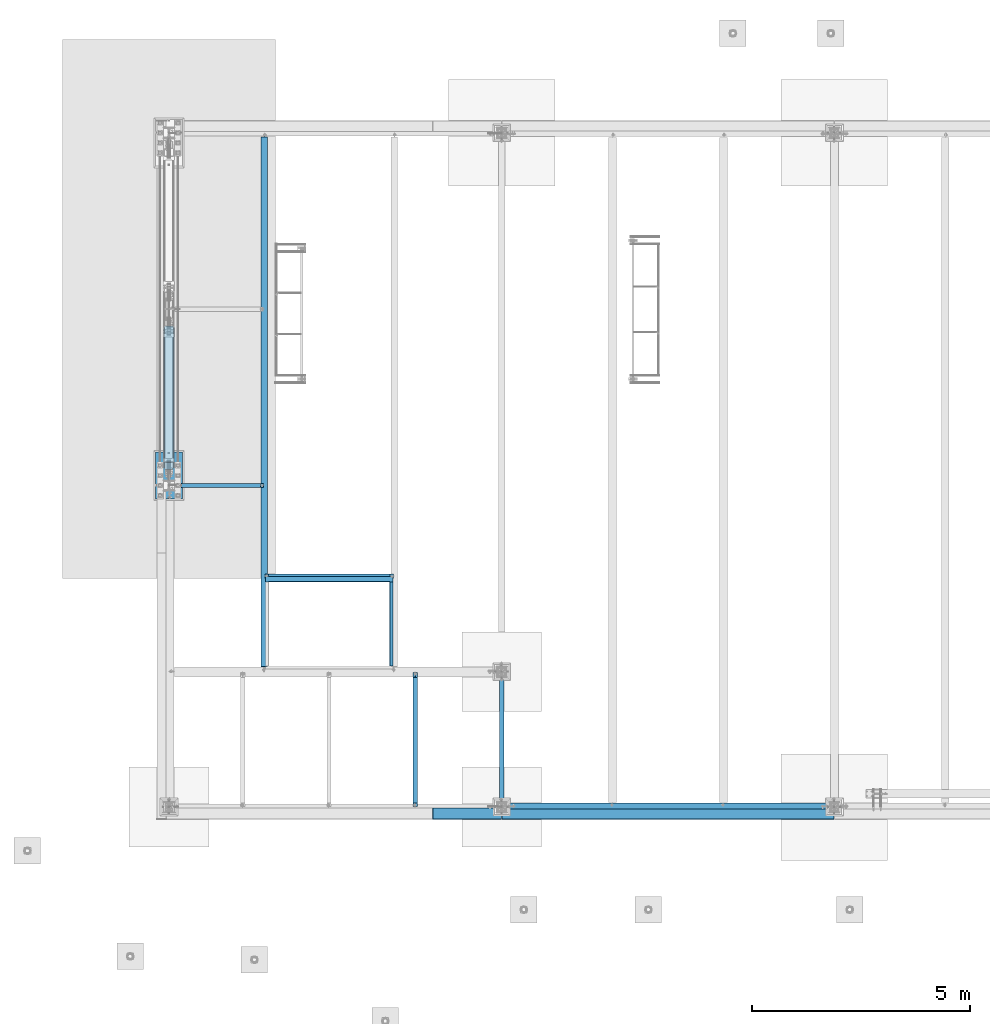
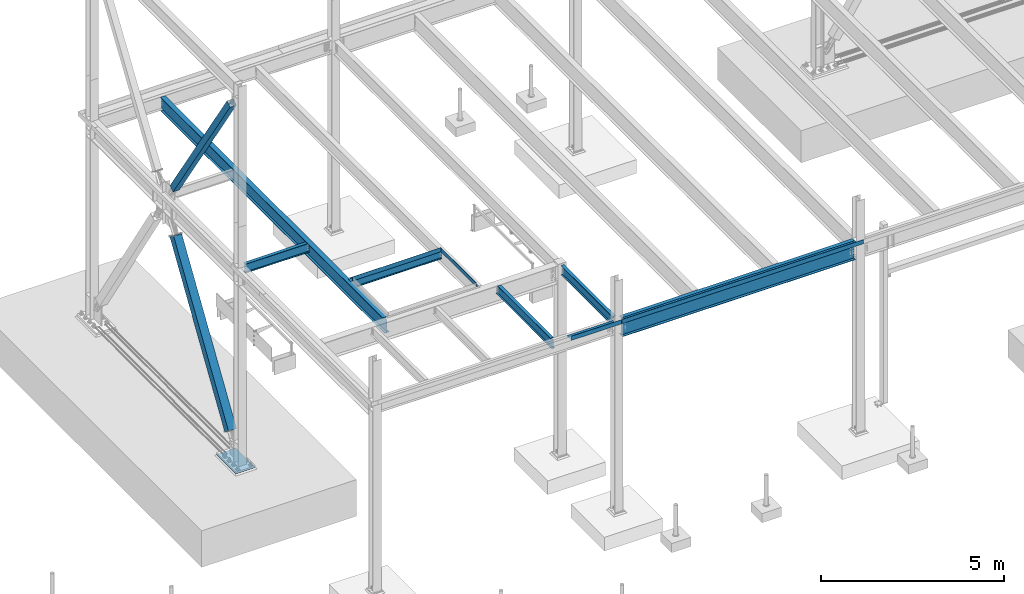
# One storey, part 1864 of 3843: 11 beams, 2 members, 11 elements without a shape of their own.
"""IFC2X3 building model written with IfcOpenShell, lengths in millimetres."""

from ifc_helpers import new_model, si_unit, frame, origin_with_axes, place, context, subcontext, project, spatial, faceted_brep, material, type_object, element, aggregate, save


model = new_model("IFC2X3")

# Units and contexts
model_context = context("Model", 3, precision=1e-05, world=origin_with_axes())
body_context = subcontext(model_context, "Body", "Model", "MODEL_VIEW")
ifc_project = project(units=[si_unit("LENGTHUNIT", "METRE", prefix="MILLI"), si_unit("AREAUNIT", "SQUARE_METRE"), si_unit("VOLUMEUNIT", "CUBIC_METRE"), si_unit("MASSUNIT", "GRAM", prefix="KILO"), si_unit("TIMEUNIT", "SECOND"), si_unit("PLANEANGLEUNIT", "RADIAN"), si_unit("SOLIDANGLEUNIT", "STERADIAN"), si_unit("THERMODYNAMICTEMPERATUREUNIT", "DEGREE_CELSIUS"), si_unit("LUMINOUSINTENSITYUNIT", "LUMEN")], contexts=[model_context])

# Site, building, storey
site_placement = place(None, origin_with_axes())
site = spatial("IfcSite", under=ifc_project, at=site_placement, CompositionType="ELEMENT")
building_placement = place(site_placement, origin_with_axes())
building = spatial("IfcBuilding", under=site, at=building_placement, Name="Undefined", CompositionType="ELEMENT")
storey_placement = place(building_placement, origin_with_axes())
storey = spatial("IfcBuildingStorey", under=building, at=storey_placement, Name="Undefined", CompositionType="ELEMENT", Elevation=0.0)

# Assembly, beam
assembly_1_placement = place(storey_placement, origin_with_axes())
assembly_1 = element("IfcElementAssembly", 1, at=assembly_1_placement, inside=storey, Name="BEAM", AssemblyPlace="NOTDEFINED", PredefinedType="RIGID_FRAME")
ifc_material_1 = material(Name="STEEL/A36")
beam_type_1 = type_object("IfcBeamType", PredefinedType="NOTDEFINED")
beam_1_placement = place(assembly_1_placement, frame((5130.8, 93306.89925, 36439.475), z_axis=(0.0, -1.0, 0.0), x_axis=(-1.0, 0.0, 0.0)))
beam_1 = element("IfcBeam", 2, at=beam_1_placement, type_object=beam_type_1, material=ifc_material_1, Name="BENT_PLATE", context=body_context, shape_type="Brep", body=[
    faceted_brep([(0.0, -3.17500000000291, -964.406000000003), (0.0, -3.17500000000291, 964.406000000003), (0.0, 3.17500000000291, 964.406000000003), (0.0, 3.17500000000291, -964.406000000003), (76.1999969482395, 3.17500000000291, 964.406000000003), (76.1999969482395, 3.17500000000291, -964.406000000003), (69.8499969482391, -3.17500000000291, -964.406000000003), (69.8499969482391, -3.17500000000291, 964.406000000003), (76.1999969482395, -136.524996948239, 964.406000000003), (76.1999969482395, -136.524996948239, -964.406000000003), (69.8499969482391, -136.524996948239, 964.406000000003), (69.8499969482391, -136.524996948239, -964.406000000003)], [[[0, 1, 2, 3]], [[3, 2, 4, 5]], [[1, 0, 6, 7]], [[5, 4, 8, 9]], [[4, 2, 1, 7, 10, 8]], [[7, 6, 11, 10]], [[6, 0, 3, 5, 9, 11]], [[10, 11, 9, 8]]]),
])
aggregate(assembly_1, [beam_1])

assembly_2_placement = place(storey_placement, origin_with_axes())
assembly_2 = element("IfcElementAssembly", 3, at=assembly_2_placement, inside=storey, Name="BEAM", AssemblyPlace="NOTDEFINED", PredefinedType="RIGID_FRAME")
ifc_material_2 = material(Name="STEEL/A992")
beam_type_2 = type_object("IfcBeamType", Name="W12X19", PredefinedType="NOTDEFINED")
beam_2_placement = place(assembly_2_placement, frame((7620.0, 89115.9, 36282.3125), z_axis=(0.0, 0.0, 1.0), x_axis=(0.0, 1.0, 0.0)))
beam_2 = element("IfcBeam", 4, at=beam_2_placement, type_object=beam_type_2, material=ifc_material_2, Name="BEAM", ObjectType="W12X19", context=body_context, shape_type="Brep", body=[
    faceted_brep([(139.699999999997, -50.8000000000002, -153.987500000003), (139.699999999997, 50.8000000000002, -153.987500000003), (2959.10000000001, 50.8000000000002, -153.987500000003), (2959.10000000001, -50.8000000000002, -153.987500000003), (139.699999999997, -50.8000000000002, -144.462500000001), (139.699999999997, -3.17500000000018, -144.462500000001), (139.699999999997, -3.17500000000018, 144.462500000001), (139.699999999997, -50.8000000000002, 144.462500000001), (139.699999999997, -50.8000000000002, 153.987500000003), (139.699999999997, 50.8000000000002, 153.987500000003), (139.699999999997, 50.8000000000002, 144.462500000001), (139.699999999997, 3.17500000000018, 144.462500000001), (139.699999999997, 3.17500000000018, -144.462500000001), (139.699999999997, 50.8000000000002, -144.462500000001), (2959.10000000001, -50.8000000000002, -144.462500000001), (2959.10000000001, -3.17500000000018, -144.462500000001), (2959.10000000001, -3.17500000000018, 144.462500000001), (2959.10000000001, -50.8000000000002, 144.462500000001), (2959.10000000001, -50.8000000000002, 153.987500000003), (2959.10000000001, 50.8000000000002, 153.987500000003), (2959.10000000001, 50.8000000000002, 144.462500000001), (2959.10000000001, 3.17500000000018, 144.462500000001), (2959.10000000001, 3.17500000000018, -144.462500000001), (2959.10000000001, 50.8000000000002, -144.462500000001)], [[[0, 1, 2, 3]], [[0, 4, 5, 6, 7, 8, 9, 10, 11, 12, 13, 1]], [[5, 4, 14, 15]], [[6, 5, 15, 16]], [[7, 6, 16, 17]], [[8, 7, 17, 18]], [[9, 8, 18, 19]], [[10, 9, 19, 20]], [[11, 10, 20, 21]], [[12, 11, 21, 22]], [[13, 12, 22, 23]], [[1, 13, 23, 2]], [[22, 21, 20, 19, 18, 17, 16, 15, 14, 3, 2, 23]], [[4, 0, 3, 14]]]),
])
aggregate(assembly_2, [beam_2])

assembly_3_placement = place(storey_placement, origin_with_axes())
assembly_3 = element("IfcElementAssembly", 5, at=assembly_3_placement, inside=storey, Name="BEAM", AssemblyPlace="NOTDEFINED", PredefinedType="RIGID_FRAME")
beam_3_placement = place(assembly_3_placement, frame((0.0, 96481.9, 36282.3125), z_axis=(0.0, 0.0, 1.0), x_axis=(1.0, 0.0, 0.0)))
beam_3 = element("IfcBeam", 6, at=beam_3_placement, type_object=beam_type_2, material=ifc_material_2, Name="BEAM", ObjectType="W12X19", context=body_context, shape_type="Brep", body=[
    faceted_brep([(2091.53125, -50.8000000000029, 153.987500000003), (2091.53125, -50.8000000000029, 144.462500000001), (2091.53125, -3.17500000000291, 144.462500000001), (2091.53125, -3.17500000000291, 141.287499809259), (2091.53125, 3.17500000000291, 141.287499809259), (2091.53125, 3.17500000000291, 144.462500000001), (2091.53125, 50.8000000000029, 144.462500000001), (2091.53125, 50.8000000000029, 153.987500000003), (2092.49797992259, -3.17500000000291, 136.427420291213), (2092.49797992259, 3.17500000000291, 136.427420291213), (2095.25099382307, -3.17500000000291, 132.307243823059), (2095.25099382307, 3.17500000000291, 132.307243823059), (2099.37117029122, -3.17500000000291, 129.554229922585), (2099.37117029122, 3.17500000000291, 129.554229922585), (2104.23124980927, -3.17500000000291, 128.587499999994), (2104.23124980927, 3.17500000000291, 128.587499999994), (2167.73125, -3.17500000000291, 128.587499999994), (2167.73125, 3.17500000000291, 128.587499999994), (141.2875, -50.8000000000029, -153.987500000003), (141.2875, -50.8000000000029, -144.462500000001), (141.2875, -3.17500000000291, -144.462500000001), (141.2875, -3.17500000000291, 144.462500000001), (141.2875, -50.8000000000029, 144.462500000001), (141.2875, -50.8000000000029, 153.987500000003), (141.2875, 50.8000000000029, 153.987500000003), (141.2875, 50.8000000000029, 144.462500000001), (141.2875, 3.17500000000291, 144.462500000001), (141.2875, 3.17500000000291, 116.627499998925), (141.2875, 3.17500000000291, -113.45249999997), (141.2875, 3.17500000000291, -144.462500000001), (141.2875, 50.8000000000029, -144.462500000001), (141.2875, 50.8000000000029, -153.987500000003), (2167.73125, 3.17500000000291, -144.462500000001), (2167.73125, 50.8000000000029, -144.462500000001), (2167.73125, 50.8000000000029, -153.987500000003), (2167.73125, -50.8000000000029, -153.987500000003), (2167.73125, -50.8000000000029, -144.462500000001), (2167.73125, -3.17500000000291, -144.462500000001), (2167.73125, 3.17500000000291, 115.887499999997), (2167.73125, 3.17500000000291, -114.712500000001)], [[[0, 1, 2, 3, 4, 5, 6, 7]], [[8, 9, 4, 3]], [[10, 11, 9, 8]], [[12, 13, 11, 10]], [[14, 15, 13, 12]], [[16, 17, 15, 14]], [[18, 19, 20, 21, 22, 23, 24, 25, 26, 27, 28, 29, 30, 31]], [[30, 29, 32, 33]], [[31, 30, 33, 34]], [[18, 31, 34, 35]], [[19, 18, 35, 36]], [[20, 19, 36, 37]], [[12, 10, 8, 3, 2, 21, 20, 37, 16, 14]], [[22, 21, 2, 1]], [[23, 22, 1, 0]], [[24, 23, 0, 7]], [[25, 24, 7, 6]], [[26, 25, 6, 5]], [[38, 39, 32, 29, 28, 27, 26, 5, 4, 9, 11, 13, 15, 17]], [[37, 36, 35, 34, 33, 32, 39, 38, 17, 16]]]),
])
aggregate(assembly_3, [beam_3])

assembly_4_placement = place(storey_placement, origin_with_axes())
assembly_4 = element("IfcElementAssembly", 7, at=assembly_4_placement, inside=storey, Name="BEAM", AssemblyPlace="NOTDEFINED", PredefinedType="RIGID_FRAME")
beam_4_placement = place(assembly_4_placement, frame((5638.8, 89115.9, 36282.3125), z_axis=(0.0, 0.0, 1.0), x_axis=(0.0, 1.0, 0.0)))
beam_4 = element("IfcBeam", 8, at=beam_4_placement, type_object=beam_type_2, material=ifc_material_2, Name="BEAM", ObjectType="W12X19", context=body_context, shape_type="Brep", body=[
    faceted_brep([(2972.59375, -50.8000000000002, 153.987499993149), (2972.59375, -50.8000000000002, 144.462500000001), (2972.59375, -3.17500000000018, 144.462500000001), (2972.59375, -3.17500000000018, 141.287499809267), (2972.59375, 3.17500000000018, 141.287499809267), (2972.59375, 3.17500000000018, 144.462500000001), (2972.59375, 50.8000000000002, 144.462500000001), (2972.59375, 50.8000000000002, 153.987500000003), (2973.56047992258, -3.17500000000018, 136.42742029122), (2973.56047992258, 3.17500000000018, 136.42742029122), (2976.31349382307, -3.17500000000018, 132.307243823067), (2976.31349382307, 3.17500000000018, 132.307243823067), (2980.43367029123, -3.17500000000018, 129.554229922593), (2980.43367029123, 3.17500000000018, 129.554229922593), (2985.29374980927, -3.17500000000018, 128.587500000001), (2985.29374980927, 3.17500000000018, 128.587500000001), (3080.54375, -3.17500000000018, 128.587500000001), (3080.54375, 3.17500000000018, 128.587500000001), (92.8687499999796, -50.8000000000002, 153.987499810319), (92.8687499999796, 50.8000000000002, 153.987500000003), (92.8687499999796, 50.8000000000002, 144.462500000001), (92.8687499999796, 3.17500000000018, 144.462500000001), (92.8687499999796, 3.17500000000018, 141.287499809259), (92.8687499999796, -3.17500000000018, 141.287499809259), (92.8687499999796, -3.17500000000018, 144.462500000001), (92.8687499999796, -50.8000000000002, 144.462500000001), (91.9020200773957, 3.17500000000018, 136.427420291213), (91.9020200773957, -3.17500000000018, 136.427420291213), (89.1490061769146, 3.17500000000018, 132.307243823059), (89.1490061769146, -3.17500000000018, 132.307243823059), (85.0288297087536, 3.17500000000018, 129.554229922585), (85.0288297087536, -3.17500000000018, 129.554229922585), (80.1687501907145, 3.17500000000018, 128.587499999994), (80.1687501907145, -3.17500000000018, 128.587499999994), (16.6687499999971, 3.17499999999927, 128.587500000001), (16.6687499999971, -3.17499999999927, 128.587500000001), (16.6687499999971, 3.17499999999927, 115.887499999742), (16.6687499999971, 3.17499999999927, -114.712500000256), (16.6687499999971, 3.17499999999927, -144.462500000001), (16.6687499999971, 50.7999999999993, -144.462500000001), (16.6687499999971, 50.7999999999993, -153.987500000003), (16.6687499999971, -50.7999999999993, -153.987500000003), (16.6687499999971, -50.7999999999993, -144.462500000001), (16.6687499999971, -3.17499999999927, -144.462500000001), (3080.54375, 3.17500000000018, -144.462500000001), (3080.54375, 50.8000000000002, -144.462500000001), (3080.54375, 50.8000000000002, -153.987500000003), (3080.54375, -50.8000000000002, -153.987500000003), (3080.54375, -50.8000000000002, -144.462500000001), (3080.54375, -3.17500000000018, -144.462500000001), (3080.54375, 3.17500000000018, 109.537499999999), (3080.54375, 3.17500000000018, -121.0625)], [[[0, 1, 2, 3, 4, 5, 6, 7]], [[8, 9, 4, 3]], [[10, 11, 9, 8]], [[12, 13, 11, 10]], [[14, 15, 13, 12]], [[16, 17, 15, 14]], [[18, 19, 20, 21, 22, 23, 24, 25]], [[23, 22, 26, 27]], [[27, 26, 28, 29]], [[29, 28, 30, 31]], [[31, 30, 32, 33]], [[33, 32, 34, 35]], [[36, 37, 38, 39, 40, 41, 42, 43, 35, 34]], [[39, 38, 44, 45]], [[40, 39, 45, 46]], [[41, 40, 46, 47]], [[42, 41, 47, 48]], [[43, 42, 48, 49]], [[12, 10, 8, 3, 2, 24, 23, 27, 29, 31, 33, 35, 43, 49, 16, 14]], [[25, 24, 2, 1]], [[18, 25, 1, 0]], [[19, 18, 0, 7]], [[20, 19, 7, 6]], [[21, 20, 6, 5]], [[50, 51, 44, 38, 37, 36, 34, 32, 30, 28, 26, 22, 21, 5, 4, 9, 11, 13, 15, 17]], [[49, 48, 47, 46, 45, 44, 51, 50, 17, 16]]]),
])
aggregate(assembly_4, [beam_4])

assembly_5_placement = place(storey_placement, origin_with_axes())
assembly_5 = element("IfcElementAssembly", 9, at=assembly_5_placement, inside=storey, Name="BEAM", AssemblyPlace="NOTDEFINED", PredefinedType="RIGID_FRAME")
beam_5_placement = place(assembly_5_placement, frame((2184.4, 94399.1, 36282.3125), z_axis=(0.0, 0.0, 1.0), x_axis=(1.0, 0.0, 0.0)))
beam_5 = element("IfcBeam", 10, at=beam_5_placement, type_object=beam_type_2, material=ifc_material_2, Name="BEAM", ObjectType="W12X19", context=body_context, shape_type="Brep", body=[
    faceted_brep([(2878.93125, -50.8000000000029, 153.987499994953), (2878.93125, -50.8000000000029, 144.462500000001), (2878.93125, -3.17500000000291, 144.462500000001), (2878.93125, -3.17500000000291, 141.287499809259), (2878.93125, 3.17500000000291, 141.287499809259), (2878.93125, 3.17500000000291, 144.462500000001), (2878.93125, 50.8000000000029, 144.462500000001), (2878.93125, 50.8000000000029, 153.987500000003), (2879.89797992259, -3.17500000000291, 136.427420291213), (2879.89797992259, 3.17500000000291, 136.427420291213), (2882.65099382307, -3.17500000000291, 132.307243823059), (2882.65099382307, 3.17500000000291, 132.307243823059), (2886.77117029122, -3.17500000000291, 129.554229922585), (2886.77117029122, 3.17500000000291, 129.554229922585), (2891.63124980927, -3.17500000000291, 128.587499999994), (2891.63124980927, 3.17500000000291, 128.587499999994), (2955.13125, -3.17500000000291, 128.587499999994), (2955.13125, 3.17500000000291, 128.587499999994), (92.8687499999796, -50.8000000000002, 153.987499810319), (92.8687499999796, 50.8000000000002, 153.987500000003), (92.8687499999796, 50.8000000000002, 144.462500000001), (92.8687499999796, 3.17500000000018, 144.462500000001), (92.8687499999796, 3.17500000000018, 141.287499809259), (92.8687499999796, -3.17500000000018, 141.287499809259), (92.8687499999796, -3.17500000000018, 144.462500000001), (92.8687499999796, -50.8000000000002, 144.462500000001), (91.9020200773957, 3.17500000000018, 136.427420291213), (91.9020200773957, -3.17500000000018, 136.427420291213), (89.1490061769146, 3.17500000000018, 132.307243823059), (89.1490061769146, -3.17500000000018, 132.307243823059), (85.0288297087536, 3.17500000000018, 129.554229922585), (85.0288297087536, -3.17500000000018, 129.554229922585), (80.1687501907145, 3.17500000000018, 128.587499999994), (80.1687501907145, -3.17500000000018, 128.587499999994), (16.6687499999971, 3.17499999999927, 128.587500000001), (16.6687499999971, -3.17499999999927, 128.587500000001), (16.6687499999971, 3.17499999999927, 115.887499999742), (16.6687499999971, 3.17499999999927, -114.712500000256), (16.6687499999971, 3.17499999999927, -144.462500000001), (16.6687499999971, 50.7999999999993, -144.462500000001), (16.6687499999971, 50.7999999999993, -153.987500000003), (16.6687499999971, -50.7999999999993, -153.987500000003), (16.6687499999971, -50.7999999999993, -144.462500000001), (16.6687499999971, -3.17499999999927, -144.462500000001), (2955.13125, 3.17500000000291, -144.462500000001), (2955.13125, 50.8000000000029, -144.462500000001), (2955.13125, 50.8000000000029, -153.987500000003), (2955.13125, -50.8000000000029, -153.987500000003), (2955.13125, -50.8000000000029, -144.462500000001), (2955.13125, -3.17500000000291, -144.462500000001), (2955.13125, 3.17500000000291, 115.887499999997), (2955.13125, 3.17500000000291, -114.712500000001)], [[[0, 1, 2, 3, 4, 5, 6, 7]], [[8, 9, 4, 3]], [[10, 11, 9, 8]], [[12, 13, 11, 10]], [[14, 15, 13, 12]], [[16, 17, 15, 14]], [[18, 19, 20, 21, 22, 23, 24, 25]], [[23, 22, 26, 27]], [[27, 26, 28, 29]], [[29, 28, 30, 31]], [[31, 30, 32, 33]], [[33, 32, 34, 35]], [[36, 37, 38, 39, 40, 41, 42, 43, 35, 34]], [[39, 38, 44, 45]], [[40, 39, 45, 46]], [[41, 40, 46, 47]], [[42, 41, 47, 48]], [[43, 42, 48, 49]], [[12, 10, 8, 3, 2, 24, 23, 27, 29, 31, 33, 35, 43, 49, 16, 14]], [[25, 24, 2, 1]], [[18, 25, 1, 0]], [[19, 18, 0, 7]], [[20, 19, 7, 6]], [[21, 20, 6, 5]], [[50, 51, 44, 38, 37, 36, 34, 32, 30, 28, 26, 22, 21, 5, 4, 9, 11, 13, 15, 17]], [[49, 48, 47, 46, 45, 44, 51, 50, 17, 16]]]),
])

# Assembly, member
assembly_6_placement = place(storey_placement, origin_with_axes())
assembly_6 = element("IfcElementAssembly", 11, at=assembly_6_placement, inside=storey, Name="None", AssemblyPlace="NOTDEFINED", PredefinedType="RIGID_FRAME")
member_type_1 = type_object("IfcMemberType", Name="HSS8X8X3/16", PredefinedType="NOTDEFINED")
member_1_placement = place(assembly_6_placement, frame((0.0, 100046.066246432, 36842.9548432704), z_axis=(-1.0, 0.0, 0.0), x_axis=(0.0, -0.551394664794348, 0.834244522688839)))
member_1 = element("IfcMember", 12, at=member_1_placement, type_object=member_type_1, material=ifc_material_2, Name="None", ObjectType="HSS8X8X3/16", context=body_context, shape_type="Brep", body=[
    faceted_brep([(2.03726813197136e-10, 96.8375000003298, -96.8374999999942), (-2.18278728425503e-10, -96.837500000317, -96.8374999999942), (5645.15000007609, -96.8375000234373, -96.8375), (5645.15000007571, 96.8374999761581, -96.8375), (-2.18278728425503e-10, -96.837500000317, 96.8374999999942), (5645.15000007609, -96.8375000234373, 96.8375), (2.03726813197136e-10, 96.8375000003298, 96.8374999999942), (5645.15000007571, 96.8374999761581, 96.8375), (2.18278728425503e-10, 101.600000000345, -101.600000000006), (2.18278728425503e-10, 101.600000000345, 101.600000000006), (5645.15000007569, 101.599999976141, 101.6), (5645.15000007569, 101.599999976141, -101.6), (-2.25554686039686e-10, -101.600000000329, 101.600000000006), (5645.15000007609, -101.600000023427, 101.6), (-2.25554686039686e-10, -101.600000000329, -101.600000000006), (5645.15000007609, -101.600000023427, -101.6)], [[[0, 1, 2, 3]], [[1, 4, 5, 2]], [[4, 6, 7, 5]], [[6, 0, 3, 7]], [[8, 9, 10, 11]], [[9, 12, 13, 10]], [[12, 14, 15, 13]], [[14, 8, 11, 15]], [[13, 15, 11, 10], [5, 7, 3, 2]], [[14, 12, 9, 8], [6, 4, 1, 0]]]),
])
aggregate(assembly_6, [member_1])

assembly_7_placement = place(storey_placement, origin_with_axes())
assembly_7 = element("IfcElementAssembly", 13, at=assembly_7_placement, inside=storey, Name="None", AssemblyPlace="NOTDEFINED", PredefinedType="RIGID_FRAME")
member_type_2 = type_object("IfcMemberType", Name="HSS10X10X1/4", PredefinedType="NOTDEFINED")
member_2_placement = place(assembly_7_placement, frame((0.0, 96993.9112571612, 30619.013802838), z_axis=(1.0, 0.0, 0.0), x_axis=(0.0, 0.539342435088305, 0.842086538137867)))
member_2 = element("IfcMember", 14, at=member_2_placement, type_object=member_type_2, material=ifc_material_2, Name="None", ObjectType="HSS10X10X1/4", context=body_context, shape_type="Brep", body=[
    faceted_brep([(2.00088834390044e-10, 120.650000000089, -120.649999999994), (-2.03726813197136e-10, -120.650000000081, -120.649999999994), (5556.24999997832, -120.650000014612, -120.65), (5556.24999997871, 120.649999984533, -120.65), (-2.03726813197136e-10, -120.650000000081, 120.649999999994), (5556.24999997832, -120.650000014612, 120.65), (2.00088834390044e-10, 120.650000000089, 120.649999999994), (5556.24999997871, 120.649999984533, 120.65), (2.16459739021957e-10, 127.000000000087, -127.0), (2.16459739021957e-10, 127.000000000087, 127.0), (5556.24999997871, 126.999999984517, 127.0), (5556.24999997871, 126.999999984517, -127.0), (-2.14640749618411e-10, -127.00000000008, 127.0), (5556.2499999783, -127.000000014588, 127.0), (-2.14640749618411e-10, -127.00000000008, -127.0), (5556.2499999783, -127.000000014588, -127.0)], [[[0, 1, 2, 3]], [[1, 4, 5, 2]], [[4, 6, 7, 5]], [[6, 0, 3, 7]], [[8, 9, 10, 11]], [[9, 12, 13, 10]], [[12, 14, 15, 13]], [[14, 8, 11, 15]], [[13, 15, 11, 10], [5, 7, 3, 2]], [[14, 12, 9, 8], [6, 4, 1, 0]]]),
])
aggregate(assembly_7, [member_2])

# Assembly, beam
assembly_8_placement = place(storey_placement, origin_with_axes())
assembly_8 = element("IfcElementAssembly", 15, at=assembly_8_placement, inside=storey, Name="BEAM", AssemblyPlace="NOTDEFINED", PredefinedType="RIGID_FRAME")
beam_type_3 = type_object("IfcBeamType", PredefinedType="NOTDEFINED")
beam_6_placement = place(assembly_8_placement, frame((6827.8375, 89090.5, 36439.475), z_axis=(-1.0, 0.0, 0.0), x_axis=(0.0, -1.0, 0.0)))
beam_6 = element("IfcBeam", 16, at=beam_6_placement, type_object=beam_type_3, material=ifc_material_1, Name="BENT_PLATE", context=body_context, shape_type="Brep", body=[
    faceted_brep([(250.824999952325, 4.76866262033582e-08, 788.9875), (247.649999999994, 3.17500000000291, 785.812500047686), (0.0, 3.17500000000291, 785.812500047682), (1.80807546712458e-09, 2.85952410195023e-06, 788.98750000447), (250.824999952325, 136.524996948247, 788.9875), (247.649999999994, 136.524996948247, 785.812500047686), (247.649999999994, 3.17500000000291, -788.9875), (114.300006103556, 3.17500000000291, -788.9875), (114.300006103556, 3.17500000000291, -652.462506103457), (0.0, 3.17500000000291, -652.462506103507), (114.300006103556, -3.17500000000291, -652.462506103457), (114.300006103556, -3.17500000000291, -788.9875), (0.0, -3.17500000000291, -652.462506103507), (0.0, -3.17500000000291, 788.9875), (254.0, -3.17500000000291, 788.9875), (254.0, 136.524996948247, 788.9875), (247.649999999994, 136.524996948247, -788.9875), (254.0, 136.524996948247, -788.9875), (254.0, -3.17500000000291, -788.9875)], [[[0, 1, 2, 3]], [[4, 5, 1, 0]], [[6, 7, 8, 9, 2, 1]], [[10, 8, 7, 11]], [[12, 9, 8, 10]], [[13, 14, 15, 4, 0, 3]], [[16, 6, 1, 5]], [[15, 17, 16, 5, 4]], [[14, 18, 17, 15]], [[6, 16, 17, 18, 11, 7]], [[9, 12, 13, 3, 2]], [[18, 14, 13, 12, 10, 11]]]),
])
aggregate(assembly_8, [beam_6])

# Beam
beam_type_4 = type_object("IfcBeamType", PredefinedType="NOTDEFINED")
beam_7_placement = place(assembly_5_placement, frame((3670.30025, 94399.1, 36439.475), z_axis=(-1.0, 0.0, 0.0), x_axis=(0.0, -1.0, 0.0)))
beam_7 = element("IfcBeam", 17, at=beam_7_placement, type_object=beam_type_4, material=ifc_material_1, Name="BENT_PLATE", context=body_context, shape_type="Brep", body=[
    faceted_brep([(127.0, 136.524996948239, 1390.64975103759), (120.649999999994, 136.524996948239, 1390.64975103759), (120.649999999994, 3.17500000000291, 1390.64975103759), (127.0, 3.17500000002474, 1390.64975103759), (127.0, 3.17500000001746, 1461.2935), (120.649999999994, 3.17500000000291, 1461.2935), (0.0, -3.17500000000291, 1461.2935), (0.0, -3.17500000000291, -1461.2935), (127.0, -3.17500000000291, -1461.2935), (127.0, -3.17500000000291, 1461.2935), (0.0, 3.17500000000291, 1461.2935), (0.0, 3.17500000000291, -1390.64975305176), (0.0, 3.17500000000291, -1461.2935), (0.0, 3.17500000000291, 1390.64975103759), (120.649999999994, 3.17500000000291, -1461.2935), (127.0, 3.17499999998836, -1461.2935), (127.0, 3.17499999997381, -1390.64975305176), (120.649999999994, 3.17500000000291, -1390.64975305176), (120.649999999994, 136.524996948239, -1390.64975305176), (127.0, 136.524996948239, -1390.64975305176)], [[[0, 1, 2, 3]], [[4, 3, 2, 5]], [[6, 7, 8, 9]], [[10, 6, 9, 4, 5]], [[11, 12, 7, 6, 10, 13]], [[8, 7, 12, 14, 15]], [[16, 17, 18, 19]], [[15, 14, 17, 16]], [[12, 11, 13, 10, 5, 2, 17, 14]], [[18, 17, 2, 1]], [[19, 18, 1, 0]], [[9, 8, 15, 16, 19, 0, 3, 4]]]),
])

aggregate(assembly_5, [beam_7, beam_5])

# Assembly, beam
assembly_9_placement = place(storey_placement, origin_with_axes())
assembly_9 = element("IfcElementAssembly", 18, at=assembly_9_placement, inside=storey, Name="BEAM", AssemblyPlace="NOTDEFINED", PredefinedType="RIGID_FRAME")
beam_type_5 = type_object("IfcBeamType", PredefinedType="NOTDEFINED")
beam_8_placement = place(assembly_9_placement, frame((11430.0, 89077.8, 36439.475), z_axis=(-1.0, 0.0, 0.0), x_axis=(0.0, -1.0, 0.0)))
beam_8 = element("IfcBeam", 19, at=beam_8_placement, type_object=beam_type_5, material=ifc_material_1, Name="BENT_PLATE", context=body_context, shape_type="Brep", body=[
    faceted_brep([(101.599996948149, -3.17499999999563, 3670.30000000001), (101.599996948149, 3.17500000000291, 3670.30000000001), (0.0, 3.17500000000291, 3670.30000000001), (0.0, -3.17500000000291, 3670.30000000001), (101.599996948149, -3.17499999999563, 3806.825), (101.599996948149, 3.17500000000291, 3806.825), (0.0, -3.17500000000291, -3670.3000061035), (0.0, 3.17500000000291, -3670.3000061035), (101.600012207025, 3.17500000000291, -3670.30000610346), (101.600012207025, -3.17500000000291, -3670.30000610346), (101.600012207025, 3.17500000000291, -3806.825), (101.600012207025, -3.17500000000291, -3806.825), (234.950003051752, 3.17500000000291, -3806.825), (234.950003051752, 136.524996948247, -3806.825), (241.300003051758, 136.524996948247, -3806.825), (241.300003051758, -3.17500000000291, -3806.825), (234.950003051752, 3.17500000000291, 3806.825), (234.950003051752, 136.524996948247, 3806.825), (241.300003051758, 136.524996948247, 3806.825), (241.300003051758, -3.17500000000291, 3806.825)], [[[0, 1, 2, 3]], [[4, 5, 1, 0]], [[6, 7, 8, 9]], [[9, 8, 10, 11]], [[12, 13, 14, 15, 11, 10]], [[12, 16, 17, 13]], [[18, 14, 13, 17]], [[19, 15, 14, 18]], [[3, 6, 9, 11, 15, 19, 4, 0]], [[7, 6, 3, 2]], [[16, 12, 10, 8, 7, 2, 1, 5]], [[19, 18, 17, 16, 5, 4]]]),
])

assembly_10_placement = place(storey_placement, origin_with_axes())
assembly_10 = element("IfcElementAssembly", 20, at=assembly_10_placement, inside=storey, Name="BEAM", AssemblyPlace="NOTDEFINED", PredefinedType="RIGID_FRAME")
beam_type_6 = type_object("IfcBeamType", Name="W18X40", PredefinedType="NOTDEFINED")
beam_9_placement = place(assembly_10_placement, frame((2184.4, 92214.7, 36209.2875), z_axis=(0.0, 0.0, 1.0), x_axis=(0.0, 1.0, 0.0)))
beam_9 = element("IfcBeam", 21, at=beam_9_placement, type_object=beam_type_6, material=ifc_material_2, Name="BEAM", ObjectType="W18X40", context=body_context, shape_type="Brep", body=[
    faceted_brep([(12254.70625, -76.1999999999998, -227.012499999997), (12254.70625, 76.1999999999998, -227.012499999997), (12254.70625, 76.1999999999998, -214.57249980927), (12254.70625, -76.1999999999998, -214.57249980927), (12254.7579671776, -3.96875, -214.3125), (12254.7579671776, -76.1999999999998, -214.3125), (12254.7579671776, 76.1999999999998, -214.3125), (12254.7579671776, 3.96875, -214.3125), (12255.6729799226, 3.96875, -209.712420291224), (12255.6729799226, -3.96875, -209.712420291224), (12258.4259938231, 3.96875, -205.59224382307), (12258.4259938231, -3.96875, -205.59224382307), (12262.5461702912, 3.96875, -202.839229922596), (12262.5461702912, -3.96875, -202.839229922596), (12267.4062498093, 3.96875, -201.872500000005), (12267.4062498093, -3.96875, -201.872500000005), (12327.73125, -3.96875, -201.872500000005), (12327.73125, 3.96875, -201.872500000005), (126.206249999988, 3.96875, 214.3125), (126.206249999988, 76.1999999999998, 214.3125), (12254.70625, 76.1999999999998, 214.3125), (12254.70625, 3.96875, 214.3125), (18.2562499999767, 3.96875, 182.5625), (18.2562499999767, 3.96875, -124.237500000003), (18.2562499999767, 3.96875, -214.3125), (18.2562499999767, 76.1999999999998, -214.3125), (18.2562499999767, 76.1999999999998, -227.012499999997), (18.2562499999767, -76.1999999999998, -227.012499999997), (18.2562499999767, -76.1999999999998, -214.3125), (18.2562499999767, -3.96875, -214.3125), (18.2562499999767, -3.96875, 195.262499999997), (18.2562499999767, 3.96875, 195.262499999997), (113.506250190723, -3.96875, 195.262499999997), (113.506250190723, 3.96875, 195.262499999997), (118.366329708762, -3.96875, 196.229229922588), (118.366329708762, 3.96875, 196.229229922588), (122.486506176923, -3.96875, 198.982243823062), (122.486506176923, 3.96875, 198.982243823062), (125.239520077404, -3.96875, 203.102420291216), (125.239520077404, 3.96875, 203.102420291216), (126.206249999988, -3.96875, 207.962499809262), (126.206249999988, 3.96875, 207.962499809262), (126.206249999988, -76.1999999999998, 227.012499999997), (126.206249999988, 76.1999999999998, 227.012499999997), (126.206249999988, -3.96875, 214.3125), (126.206249999988, -76.1999999999998, 214.3125), (12254.70625, -3.96875, 214.3125), (12254.70625, -76.1999999999998, 214.3125), (12254.70625, -76.1999999999998, 227.012499999997), (12254.70625, 76.1999999999998, 227.012499999997), (12254.70625, -3.96875, 214.052499809259), (12254.70625, 3.96875, 214.052499809259), (12255.6729799226, -3.96875, 209.192420291212), (12255.6729799226, 3.96875, 209.192420291212), (12258.4259938231, -3.96875, 205.072243823059), (12258.4259938231, 3.96875, 205.072243823059), (12262.5461702912, -3.96875, 202.319229922585), (12262.5461702912, 3.96875, 202.319229922585), (12267.4062498093, -3.96875, 201.352499999994), (12267.4062498093, 3.96875, 201.352499999994), (12327.73125, -3.96875, 201.352499999994), (12327.73125, 3.96875, 201.352499999994)], [[[0, 1, 2, 3]], [[4, 5, 3, 2, 6, 7, 8, 9]], [[9, 8, 10, 11]], [[11, 10, 12, 13]], [[13, 12, 14, 15]], [[16, 15, 14, 17]], [[18, 19, 20, 21]], [[22, 23, 24, 25, 26, 27, 28, 29, 30, 31]], [[32, 33, 31, 30]], [[34, 35, 33, 32]], [[36, 37, 35, 34]], [[38, 39, 37, 36]], [[40, 41, 39, 38]], [[42, 43, 19, 18, 41, 40, 44, 45]], [[45, 44, 46, 47]], [[42, 45, 47, 48]], [[43, 42, 48, 49]], [[19, 43, 49, 20]], [[48, 47, 46, 50, 51, 21, 20, 49]], [[52, 53, 51, 50]], [[54, 55, 53, 52]], [[56, 57, 55, 54]], [[58, 59, 57, 56]], [[60, 61, 59, 58]], [[61, 60, 16, 17]], [[12, 10, 8, 7, 24, 23, 22, 31, 33, 35, 37, 39, 41, 18, 21, 51, 53, 55, 57, 59, 61, 17, 14]], [[25, 24, 7, 6]], [[1, 26, 25, 6, 2]], [[27, 26, 1, 0]], [[28, 27, 0, 3, 5]], [[29, 28, 5, 4]], [[60, 58, 56, 54, 52, 50, 46, 44, 40, 38, 36, 34, 32, 30, 29, 4, 9, 11, 13, 15, 16]]]),
])
aggregate(assembly_10, [beam_9])

# Beam
beam_type_7 = type_object("IfcBeamType", Name="W24X55", PredefinedType="NOTDEFINED")
beam_10_placement = place(assembly_9_placement, frame((7620.0, 89115.9, 36136.2625), z_axis=(0.0, 0.0, 1.0), x_axis=(1.0, 0.0, 0.0)))
beam_10 = element("IfcBeam", 22, at=beam_10_placement, type_object=beam_type_7, material=ifc_material_2, Name="BEAM", ObjectType="W24X55", context=body_context, shape_type="Brep", body=[
    faceted_brep([(139.699999999997, -88.8999999999996, -300.037499999999), (139.699999999997, 88.8999999999996, -300.037499999999), (7480.3, 88.8999999999942, -300.037499999999), (7480.3, -88.8999999999942, -300.037499999999), (139.699999999997, -88.8999999999996, -287.337500000001), (139.699999999997, -4.76250000000073, -287.337500000001), (139.699999999997, -4.76250000000073, 287.337500000001), (139.699999999997, -88.8999999999996, 287.337500000001), (139.699999999997, -88.8999999999996, 300.037499999999), (139.699999999997, 88.8999999999996, 300.037499999999), (139.699999999997, 88.8999999999996, 287.337500000001), (139.699999999997, 4.76250000000073, 287.337500000001), (139.7, 4.76249999999709, 262.677499999998), (139.7, 4.76249999999709, -208.702493896482), (139.699999999997, 4.76250000000073, -287.337500000001), (139.699999999997, 88.8999999999996, -287.337500000001), (7480.3, -88.8999999999942, -287.337500000001), (7480.3, -4.76249999999709, -287.337500000001), (7480.3, -4.76249999999709, 287.337500000001), (7480.3, -88.8999999999942, 287.337500000001), (7480.3, -88.8999999999942, 300.037499999999), (7480.3, 88.8999999999942, 300.037499999999), (7480.3, 88.8999999999942, 287.337500000001), (7480.3, 4.76249999999709, 287.337500000001), (7480.3, 4.76249999999709, 262.677499999998), (7480.3, 4.76249999999709, -208.702493896482), (7480.3, 4.76249999999709, -287.337500000001), (7480.3, 88.8999999999942, -287.337500000001)], [[[0, 1, 2, 3]], [[0, 4, 5, 6, 7, 8, 9, 10, 11, 12, 13, 14, 15, 1]], [[5, 4, 16, 17]], [[6, 5, 17, 18]], [[7, 6, 18, 19]], [[8, 7, 19, 20]], [[9, 8, 20, 21]], [[10, 9, 21, 22]], [[11, 10, 22, 23]], [[14, 13, 12, 11, 23, 24, 25, 26]], [[15, 14, 26, 27]], [[1, 15, 27, 2]], [[26, 25, 24, 23, 22, 21, 20, 19, 18, 17, 16, 3, 2, 27]], [[4, 0, 3, 16]]]),
])

aggregate(assembly_9, [beam_8, beam_10])

# Assembly, beam
assembly_11_placement = place(storey_placement, origin_with_axes())
assembly_11 = element("IfcElementAssembly", 23, at=assembly_11_placement, inside=storey, Name="TEMPLATE", AssemblyPlace="NOTDEFINED", PredefinedType="RIGID_FRAME")
ifc_material_3 = material(Name="STEEL/A572-50")
beam_type_8 = type_object("IfcBeamType", PredefinedType="NOTDEFINED")
beam_11_placement = place(assembly_11_placement, frame((0.0, 96177.0999938965, 29760.8625), z_axis=(-1.0, 0.0, 0.0), x_axis=(0.0, 1.0, 0.0)))
beam_11 = element("IfcBeam", 24, at=beam_11_placement, type_object=beam_type_8, material=ifc_material_3, Name="TEMPLATE", context=body_context, shape_type="Brep", body=[
    faceted_brep([(0.0, 4.76250000000073, -304.800000000003), (0.0, 4.76250000000073, 304.800000000003), (1066.80001220703, 4.76250000000073, 304.800000000003), (1066.80001220703, 4.76250000000073, -304.800000000003), (0.0, -4.76250000000073, 304.800000000003), (1066.80001220703, -4.76250000000073, 304.800000000003), (0.0, -4.76250000000073, -304.800000000003), (1066.80001220703, -4.76250000000073, -304.800000000003)], [[[0, 1, 2, 3]], [[1, 4, 5, 2]], [[4, 6, 7, 5]], [[6, 0, 3, 7]], [[5, 7, 3, 2]], [[6, 4, 1, 0]]]),
])
aggregate(assembly_11, [beam_11])

save(model, "model.ifc")
